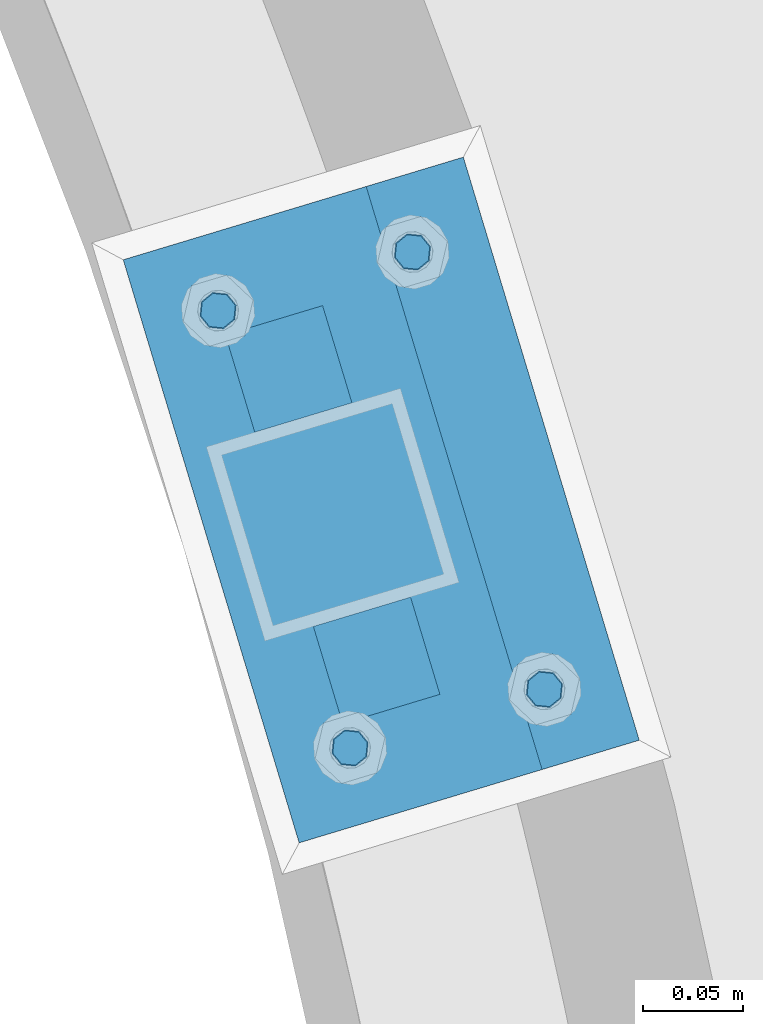
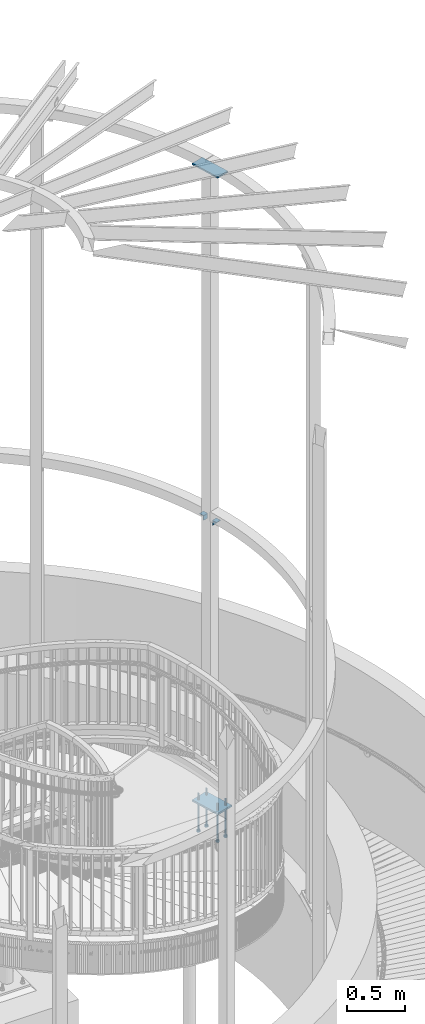
# One storey, part 512 of 975: 9 beams.
"""IFC2X3 building model written with IfcOpenShell, lengths in millimetres."""

from ifc_helpers import new_model, si_unit, frame, origin_with_axes, place, context, subcontext, project, spatial, faceted_brep, material, type_object, element, save


model = new_model("IFC2X3")

# Units and contexts
model_context = context("Model", 3, precision=1e-05, world=origin_with_axes())
body_context = subcontext(model_context, "Body", "Model", "MODEL_VIEW")
ifc_project = project(units=[si_unit("LENGTHUNIT", "METRE", prefix="MILLI"), si_unit("AREAUNIT", "SQUARE_METRE"), si_unit("VOLUMEUNIT", "CUBIC_METRE"), si_unit("MASSUNIT", "GRAM", prefix="KILO"), si_unit("TIMEUNIT", "SECOND"), si_unit("PLANEANGLEUNIT", "RADIAN"), si_unit("SOLIDANGLEUNIT", "STERADIAN"), si_unit("THERMODYNAMICTEMPERATUREUNIT", "DEGREE_CELSIUS"), si_unit("LUMINOUSINTENSITYUNIT", "LUMEN")], contexts=[model_context])

# Site, building, storey
site_placement = place(None, origin_with_axes())
site = spatial("IfcSite", under=ifc_project, at=site_placement, CompositionType="ELEMENT")
building_placement = place(site_placement, origin_with_axes())
building = spatial("IfcBuilding", under=site, at=building_placement, Name="Undefined", CompositionType="ELEMENT")
storey_placement = place(building_placement, origin_with_axes())
storey = spatial("IfcBuildingStorey", under=building, at=storey_placement, Name="Undefined", CompositionType="ELEMENT", Elevation=0.0)

# Beams
ifc_material_1 = material(Name="STEEL/A36")
beam_type_1 = type_object("IfcBeamType", Name="L2X2X1/4", PredefinedType="NOTDEFINED")
for number, where, z_axis, x_axis, name in (
    (1, (37884.2855508287, 4274.3875025586, 4445.0), (0.288864709123643, -0.957369928409553, 0.0), (0.957369928409554, 0.288864709123642, 0.0), "ANGLE"),
    (2, (37888.8969615215, 4434.96500687169, 4445.0), (-0.288864709123643, 0.957369928409553, 0.0), (-0.957369928409554, -0.288864709123642, 0.0), "ANGLE"),
):
    element("IfcBeam", number, at=place(storey_placement, frame(where, z_axis=z_axis, x_axis=x_axis)), inside=storey, type_object=beam_type_1, material=ifc_material_1, Name=name, ObjectType="L2X2X1/4", context=body_context, shape_type="Brep", body=[
        faceted_brep([(0.0, 25.3999999999724, -25.4000000000342), (0.0, 25.400000000016, 25.4000000000196), (50.8000000000102, 25.3999999999996, 25.4000000000015), (50.7999999999411, 25.3999999999996, -25.4000000000487), (3.27418092638254e-11, 19.0500000000002, 25.4000000000269), (50.8000000000102, 19.0500000000002, 25.4000000000015), (-2.5465851649642e-11, 19.0500000000002, -19.0500000000211), (50.7999999999483, 19.0500000000002, -19.0500000000429), (-2.5465851649642e-11, -25.3999999999996, -19.0500000000211), (50.7999999999483, -25.3999999999996, -19.0500000000429), (0.0, -25.400000000016, -25.4000000000196), (50.7999999999411, -25.3999999999996, -25.4000000000487)], [[[0, 1, 2, 3]], [[1, 4, 5, 2]], [[4, 6, 7, 5]], [[6, 8, 9, 7]], [[8, 10, 11, 9]], [[10, 0, 3, 11]], [[5, 7, 9, 11, 3, 2]], [[10, 8, 6, 4, 1, 0]]]),
    ])
beam_type_2 = type_object("IfcBeamType", PredefinedType="NOTDEFINED")
beam_1_placement = place(storey_placement, frame((37842.5682745048, 4500.57943180456, 8170.8625), z_axis=(-0.957369928409554, -0.288864709123642, 0.0), x_axis=(0.288864709123643, -0.957369928409553, 0.0)))
element("IfcBeam", 3, at=beam_1_placement, inside=storey, type_object=beam_type_2, material=ifc_material_1, Name="PLATE", context=body_context, shape_type="Brep", body=[
    faceted_brep([(0.0, 7.9375, -63.5), (0.0, 7.9375, 63.5), (304.799999999529, 7.9375, 63.5), (304.799999999529, 7.9375, -63.5), (0.0, -7.9375, 63.5), (304.799999999529, -7.9375, 63.5), (0.0, -7.9375, -63.5), (304.799999999529, -7.9375, -63.5)], [[[0, 1, 2, 3]], [[1, 4, 5, 2]], [[4, 6, 7, 5]], [[6, 0, 3, 7]], [[5, 7, 3, 2]], [[6, 4, 1, 0]]]),
])
ifc_material_2 = material(Name="STEEL/F1554-36")
beam_type_3 = type_object("IfcBeamType", PredefinedType="NOTDEFINED")
beam_2_placement = place(storey_placement, frame((37895.2912979753, 4237.91170244039, 1371.6), z_axis=(0.288864709123643, -0.957369928409553, 0.0), x_axis=(0.0, 0.0, -1.0)))
element("IfcBeam", 4, at=beam_2_placement, inside=storey, type_object=beam_type_3, material=ifc_material_2, Name="HEADED_ANCHOR_BOLT", context=body_context, shape_type="Brep", body=[
    faceted_brep([(260.34375, -9.13000011445183, 15.8100004195221), (260.34375, -18.2600002289691, -1.45519152283669e-11), (279.393749999999, -18.2600002289691, -1.45519152283669e-11), (279.393749999999, -9.13000011445183, 15.8100004195221), (260.34375, 9.13000011451732, 15.8100004195403), (279.393749999999, 9.13000011451732, 15.8100004195403), (260.34375, 18.2600002289728, 1.81898940354586e-11), (279.393749999999, 18.2600002289728, 1.81898940354586e-11), (260.34375, 9.13000011445547, -15.8100004195221), (279.393749999999, 9.13000011445547, -15.8100004195221), (260.34375, -9.13000011451732, -15.8100004195367), (279.393749999999, -9.13000011451732, -15.8100004195367), (260.34375, -4.47768005528269, 9.29799844174704), (260.34375, -8.06850066050174, 6.43441456486471), (260.34375, -10.0612557562381, 2.29641597050068), (260.34375, -10.0612557562454, -2.29641597051523), (260.34375, -8.06850066052721, -6.43441456487926), (260.34375, -4.47768005531907, -9.29799844175068), (260.34375, -1.81898940354586e-11, -10.319999694766), (260.34375, 4.47768005528633, -9.2979984417434), (260.34375, 8.06850066050174, -6.43441456486471), (260.34375, 10.0612557562381, -2.29641597050068), (260.34375, 10.0612557562454, 2.29641597051886), (260.34375, 8.06850066052357, 6.4344145648829), (260.34375, 4.47768005532271, 9.29799844175432), (260.34375, 2.18278728425503e-11, 10.3199996947696), (279.393749999999, 2.18278728425503e-11, 10.3199996947696), (279.393749999999, -4.47768005528269, 9.29799844174704), (279.393749999999, -8.06850066050174, 6.43441456486471), (279.393749999999, -10.0612557562381, 2.29641597050068), (279.393749999999, -10.0612557562454, -2.29641597051523), (279.393749999999, -8.06850066052721, -6.43441456487926), (279.393749999999, -4.47768005531907, -9.29799844175068), (279.393749999999, -1.81898940354586e-11, -10.319999694766), (279.393749999999, 4.47768005528633, -9.2979984417434), (279.393749999999, 8.06850066050174, -6.43441456486471), (279.393749999999, 10.0612557562381, -2.29641597050068), (279.393749999999, 10.0612557562454, 2.29641597051886), (279.393749999999, 8.06850066052357, 6.4344145648829), (279.393749999999, 4.47768005532271, 9.29799844175432), (0.0, -6.73519209080223, 6.73519209080186), (0.0, -9.52499999999964, 0.0), (279.400000000001, -9.52499999999782, -3.63797880709171e-12), (279.400000000001, -6.73519209079313, 6.73519209079313), (-9.87109982941227e-13, -1.20792265079217e-13, 9.52499961853027), (279.400000000001, 1.09139364212751e-11, 9.52499999999054), (0.0, 6.73519209080223, 6.73519209080186), (279.400000000001, 6.73519209081132, 6.73519209079677), (0.0, 9.52499999999964, 0.0), (279.400000000001, 9.52500000000146, 3.63797880709171e-12), (0.0, 6.73519209080223, -6.73519209080186), (279.400000000001, 6.73519209079677, -6.73519209079313), (2.95075507493764e-12, -1.20792265079217e-13, -9.52499961853027), (279.400000000001, -1.09139364212751e-11, -9.5249999999869), (-126.99791499542, -6.36396103070001, 6.3639610306418), (-126.99791499542, 1.81898940354586e-11, 8.99999999995271), (-126.99791499542, 6.36396103072184, 6.36396103065272), (-126.99791499542, 9.00000000004366, 1.09139364212751e-11), (-126.99791499542, 6.36396103069637, -6.3639610306418), (-126.99791499542, -1.81898940354586e-11, -8.99999999995271), (-126.99791499542, -6.36396103072184, -6.36396103064908), (-126.99791499542, -9.00000000004002, -7.27595761418343e-12), (0.0149743263646087, 6.36396103067818, -6.36396103067909), (0.0149743263646087, 0.0, -9.0), (0.0149743263646087, -6.36396103067818, -6.36396103067909), (0.0149743263987148, -8.9999995411581, -1.00796984270346e-06), (0.0149743263646087, -6.36396103067818, 6.36396103067909), (0.0149743263646087, 0.0, 9.0), (0.0149743263646087, 6.36396103067818, 6.36396103067909), (0.0149743263987148, 9.0000004588419, -1.00796984270346e-06), (0.0, -6.73519209080223, -6.73519209080186), (279.400000000001, -6.73519209080769, -6.73519209079677)], [[[0, 1, 2, 3]], [[4, 0, 3, 5]], [[6, 4, 5, 7]], [[8, 6, 7, 9]], [[10, 8, 9, 11]], [[0, 4, 6, 8, 10, 1], [12, 13, 14, 15, 16, 17, 18, 19, 20, 21, 22, 23, 24, 25]], [[12, 25, 26, 27]], [[13, 12, 27, 28]], [[14, 13, 28, 29]], [[15, 14, 29, 30]], [[16, 15, 30, 31]], [[17, 16, 31, 32]], [[18, 17, 32, 33]], [[19, 18, 33, 34]], [[20, 19, 34, 35]], [[21, 20, 35, 36]], [[22, 21, 36, 37]], [[23, 22, 37, 38]], [[24, 23, 38, 39]], [[25, 24, 39, 26]], [[9, 7, 5, 3, 2, 11], [38, 37, 36, 35, 34, 33, 32, 31, 30, 29, 28, 27, 26, 39]], [[1, 10, 11, 2]], [[40, 41, 42, 43]], [[44, 40, 43, 45]], [[46, 44, 45, 47]], [[48, 46, 47, 49]], [[50, 48, 49, 51]], [[52, 50, 51, 53]], [[54, 55, 56, 57, 58, 59, 60, 61]], [[59, 58, 62, 63]], [[60, 59, 63, 64]], [[61, 60, 64, 65]], [[54, 61, 65, 66]], [[55, 54, 66, 67]], [[56, 55, 67, 68]], [[57, 56, 68, 69]], [[58, 57, 69, 62]], [[40, 44, 46, 48, 50, 52, 70, 41], [68, 67, 66, 65, 64, 63, 62, 69]], [[41, 70, 71, 42]], [[53, 51, 49, 47, 45, 43, 42, 71]], [[70, 52, 53, 71]]]),
])
beam_3_placement = place(storey_placement, frame((37992.5600809474, 4267.26036270437, 1371.6), z_axis=(-0.288864709123643, 0.957369928409553, 0.0), x_axis=(0.0, 0.0, -1.0)))
element("IfcBeam", 5, at=beam_3_placement, inside=storey, type_object=beam_type_3, material=ifc_material_2, Name="HEADED_ANCHOR_BOLT", context=body_context, shape_type="Brep", body=[
    faceted_brep([(260.34375, -9.13000011445183, 15.8100004195221), (260.34375, -18.2600002289691, -1.45519152283669e-11), (279.393749999999, -18.2600002289691, -1.45519152283669e-11), (279.393749999999, -9.13000011445183, 15.8100004195221), (260.34375, 9.13000011451732, 15.8100004195403), (279.393749999999, 9.13000011451732, 15.8100004195403), (260.34375, 18.2600002289728, 1.81898940354586e-11), (279.393749999999, 18.2600002289728, 1.81898940354586e-11), (260.34375, 9.13000011445547, -15.8100004195221), (279.393749999999, 9.13000011445547, -15.8100004195221), (260.34375, -9.13000011451732, -15.8100004195367), (279.393749999999, -9.13000011451732, -15.8100004195367), (260.34375, -4.47768005528269, 9.29799844174704), (260.34375, -8.06850066050174, 6.43441456486471), (260.34375, -10.0612557562381, 2.29641597050068), (260.34375, -10.0612557562454, -2.29641597051523), (260.34375, -8.06850066052721, -6.43441456487926), (260.34375, -4.47768005531907, -9.29799844175068), (260.34375, -1.81898940354586e-11, -10.319999694766), (260.34375, 4.47768005528633, -9.2979984417434), (260.34375, 8.06850066050174, -6.43441456486471), (260.34375, 10.0612557562381, -2.29641597050068), (260.34375, 10.0612557562454, 2.29641597051886), (260.34375, 8.06850066052357, 6.4344145648829), (260.34375, 4.47768005532271, 9.29799844175432), (260.34375, 2.18278728425503e-11, 10.3199996947696), (279.393749999999, 2.18278728425503e-11, 10.3199996947696), (279.393749999999, -4.47768005528269, 9.29799844174704), (279.393749999999, -8.06850066050174, 6.43441456486471), (279.393749999999, -10.0612557562381, 2.29641597050068), (279.393749999999, -10.0612557562454, -2.29641597051523), (279.393749999999, -8.06850066052721, -6.43441456487926), (279.393749999999, -4.47768005531907, -9.29799844175068), (279.393749999999, -1.81898940354586e-11, -10.319999694766), (279.393749999999, 4.47768005528633, -9.2979984417434), (279.393749999999, 8.06850066050174, -6.43441456486471), (279.393749999999, 10.0612557562381, -2.29641597050068), (279.393749999999, 10.0612557562454, 2.29641597051886), (279.393749999999, 8.06850066052357, 6.4344145648829), (279.393749999999, 4.47768005532271, 9.29799844175432), (0.0, -6.73519209080223, 6.73519209080186), (0.0, -9.52499999999964, 0.0), (279.400000000001, -9.52499999999782, -3.63797880709171e-12), (279.400000000001, -6.73519209079313, 6.73519209079313), (-9.87109982941227e-13, -1.20792265079217e-13, 9.52499961853027), (279.400000000001, 1.09139364212751e-11, 9.52499999999054), (0.0, 6.73519209080223, 6.73519209080186), (279.400000000001, 6.73519209081132, 6.73519209079677), (0.0, 9.52499999999964, 0.0), (279.400000000001, 9.52500000000146, 3.63797880709171e-12), (0.0, 6.73519209080223, -6.73519209080186), (279.400000000001, 6.73519209079677, -6.73519209079313), (2.95075507493764e-12, -1.20792265079217e-13, -9.52499961853027), (279.400000000001, -1.09139364212751e-11, -9.5249999999869), (-126.99791499542, -6.36396103070001, 6.3639610306418), (-126.99791499542, 1.81898940354586e-11, 8.99999999995271), (-126.99791499542, 6.36396103072184, 6.36396103065272), (-126.99791499542, 9.00000000004366, 1.09139364212751e-11), (-126.99791499542, 6.36396103069637, -6.3639610306418), (-126.99791499542, -1.81898940354586e-11, -8.99999999995271), (-126.99791499542, -6.36396103072184, -6.36396103064908), (-126.99791499542, -9.00000000004002, -7.27595761418343e-12), (0.0149743263646087, 6.36396103067818, -6.36396103067909), (0.0149743263646087, 0.0, -9.0), (0.0149743263646087, -6.36396103067818, -6.36396103067909), (0.0149743263987148, -8.9999995411581, -1.00796984270346e-06), (0.0149743263646087, -6.36396103067818, 6.36396103067909), (0.0149743263646087, 0.0, 9.0), (0.0149743263646087, 6.36396103067818, 6.36396103067909), (0.0149743263987148, 9.0000004588419, -1.00796984270346e-06), (0.0, -6.73519209080223, -6.73519209080186), (279.400000000001, -6.73519209080769, -6.73519209079677)], [[[0, 1, 2, 3]], [[4, 0, 3, 5]], [[6, 4, 5, 7]], [[8, 6, 7, 9]], [[10, 8, 9, 11]], [[0, 4, 6, 8, 10, 1], [12, 13, 14, 15, 16, 17, 18, 19, 20, 21, 22, 23, 24, 25]], [[12, 25, 26, 27]], [[13, 12, 27, 28]], [[14, 13, 28, 29]], [[15, 14, 29, 30]], [[16, 15, 30, 31]], [[17, 16, 31, 32]], [[18, 17, 32, 33]], [[19, 18, 33, 34]], [[20, 19, 34, 35]], [[21, 20, 35, 36]], [[22, 21, 36, 37]], [[23, 22, 37, 38]], [[24, 23, 38, 39]], [[25, 24, 39, 26]], [[9, 7, 5, 3, 2, 11], [38, 37, 36, 35, 34, 33, 32, 31, 30, 29, 28, 27, 26, 39]], [[1, 10, 11, 2]], [[40, 41, 42, 43]], [[44, 40, 43, 45]], [[46, 44, 45, 47]], [[48, 46, 47, 49]], [[50, 48, 49, 51]], [[52, 50, 51, 53]], [[54, 55, 56, 57, 58, 59, 60, 61]], [[59, 58, 62, 63]], [[60, 59, 63, 64]], [[61, 60, 64, 65]], [[54, 61, 65, 66]], [[55, 54, 66, 67]], [[56, 55, 67, 68]], [[57, 56, 68, 69]], [[58, 57, 69, 62]], [[40, 44, 46, 48, 50, 52, 70, 41], [68, 67, 66, 65, 64, 63, 62, 69]], [[41, 70, 71, 42]], [[53, 51, 49, 47, 45, 43, 42, 71]], [[70, 52, 53, 71]]]),
])
beam_4_placement = place(storey_placement, frame((37829.2568255331, 4456.76646809366, 1371.6), z_axis=(0.288864709123643, -0.957369928409553, 0.0), x_axis=(0.0, 0.0, -1.0)))
element("IfcBeam", 6, at=beam_4_placement, inside=storey, type_object=beam_type_3, material=ifc_material_2, Name="HEADED_ANCHOR_BOLT", context=body_context, shape_type="Brep", body=[
    faceted_brep([(260.34375, -9.13000011445183, 15.8100004195221), (260.34375, -18.2600002289691, -1.45519152283669e-11), (279.393749999999, -18.2600002289691, -1.45519152283669e-11), (279.393749999999, -9.13000011445183, 15.8100004195221), (260.34375, 9.13000011451732, 15.8100004195403), (279.393749999999, 9.13000011451732, 15.8100004195403), (260.34375, 18.2600002289728, 1.81898940354586e-11), (279.393749999999, 18.2600002289728, 1.81898940354586e-11), (260.34375, 9.13000011445547, -15.8100004195221), (279.393749999999, 9.13000011445547, -15.8100004195221), (260.34375, -9.13000011451732, -15.8100004195367), (279.393749999999, -9.13000011451732, -15.8100004195367), (260.34375, -4.47768005528269, 9.29799844174704), (260.34375, -8.06850066050174, 6.43441456486471), (260.34375, -10.0612557562381, 2.29641597050068), (260.34375, -10.0612557562454, -2.29641597051523), (260.34375, -8.06850066052721, -6.43441456487926), (260.34375, -4.47768005531907, -9.29799844175068), (260.34375, -1.81898940354586e-11, -10.319999694766), (260.34375, 4.47768005528633, -9.2979984417434), (260.34375, 8.06850066050174, -6.43441456486471), (260.34375, 10.0612557562381, -2.29641597050068), (260.34375, 10.0612557562454, 2.29641597051886), (260.34375, 8.06850066052357, 6.4344145648829), (260.34375, 4.47768005532271, 9.29799844175432), (260.34375, 2.18278728425503e-11, 10.3199996947696), (279.393749999999, 2.18278728425503e-11, 10.3199996947696), (279.393749999999, -4.47768005528269, 9.29799844174704), (279.393749999999, -8.06850066050174, 6.43441456486471), (279.393749999999, -10.0612557562381, 2.29641597050068), (279.393749999999, -10.0612557562454, -2.29641597051523), (279.393749999999, -8.06850066052721, -6.43441456487926), (279.393749999999, -4.47768005531907, -9.29799844175068), (279.393749999999, -1.81898940354586e-11, -10.319999694766), (279.393749999999, 4.47768005528633, -9.2979984417434), (279.393749999999, 8.06850066050174, -6.43441456486471), (279.393749999999, 10.0612557562381, -2.29641597050068), (279.393749999999, 10.0612557562454, 2.29641597051886), (279.393749999999, 8.06850066052357, 6.4344145648829), (279.393749999999, 4.47768005532271, 9.29799844175432), (0.0, -6.73519209080223, 6.73519209080186), (0.0, -9.52499999999964, 0.0), (279.400000000001, -9.52499999999782, -3.63797880709171e-12), (279.400000000001, -6.73519209079313, 6.73519209079313), (-9.87109982941227e-13, -1.20792265079217e-13, 9.52499961853027), (279.400000000001, 1.09139364212751e-11, 9.52499999999054), (0.0, 6.73519209080223, 6.73519209080186), (279.400000000001, 6.73519209081132, 6.73519209079677), (0.0, 9.52499999999964, 0.0), (279.400000000001, 9.52500000000146, 3.63797880709171e-12), (0.0, 6.73519209080223, -6.73519209080186), (279.400000000001, 6.73519209079677, -6.73519209079313), (2.95075507493764e-12, -1.20792265079217e-13, -9.52499961853027), (279.400000000001, -1.09139364212751e-11, -9.5249999999869), (-126.99791499542, -6.36396103070001, 6.3639610306418), (-126.99791499542, 1.81898940354586e-11, 8.99999999995271), (-126.99791499542, 6.36396103072184, 6.36396103065272), (-126.99791499542, 9.00000000004366, 1.09139364212751e-11), (-126.99791499542, 6.36396103069637, -6.3639610306418), (-126.99791499542, -1.81898940354586e-11, -8.99999999995271), (-126.99791499542, -6.36396103072184, -6.36396103064908), (-126.99791499542, -9.00000000004002, -7.27595761418343e-12), (0.0149743263646087, 6.36396103067818, -6.36396103067909), (0.0149743263646087, 0.0, -9.0), (0.0149743263646087, -6.36396103067818, -6.36396103067909), (0.0149743263987148, -8.9999995411581, -1.00796984270346e-06), (0.0149743263646087, -6.36396103067818, 6.36396103067909), (0.0149743263646087, 0.0, 9.0), (0.0149743263646087, 6.36396103067818, 6.36396103067909), (0.0149743263987148, 9.0000004588419, -1.00796984270346e-06), (0.0, -6.73519209080223, -6.73519209080186), (279.400000000001, -6.73519209080769, -6.73519209079677)], [[[0, 1, 2, 3]], [[4, 0, 3, 5]], [[6, 4, 5, 7]], [[8, 6, 7, 9]], [[10, 8, 9, 11]], [[0, 4, 6, 8, 10, 1], [12, 13, 14, 15, 16, 17, 18, 19, 20, 21, 22, 23, 24, 25]], [[12, 25, 26, 27]], [[13, 12, 27, 28]], [[14, 13, 28, 29]], [[15, 14, 29, 30]], [[16, 15, 30, 31]], [[17, 16, 31, 32]], [[18, 17, 32, 33]], [[19, 18, 33, 34]], [[20, 19, 34, 35]], [[21, 20, 35, 36]], [[22, 21, 36, 37]], [[23, 22, 37, 38]], [[24, 23, 38, 39]], [[25, 24, 39, 26]], [[9, 7, 5, 3, 2, 11], [38, 37, 36, 35, 34, 33, 32, 31, 30, 29, 28, 27, 26, 39]], [[1, 10, 11, 2]], [[40, 41, 42, 43]], [[44, 40, 43, 45]], [[46, 44, 45, 47]], [[48, 46, 47, 49]], [[50, 48, 49, 51]], [[52, 50, 51, 53]], [[54, 55, 56, 57, 58, 59, 60, 61]], [[59, 58, 62, 63]], [[60, 59, 63, 64]], [[61, 60, 64, 65]], [[54, 61, 65, 66]], [[55, 54, 66, 67]], [[56, 55, 67, 68]], [[57, 56, 68, 69]], [[58, 57, 69, 62]], [[40, 44, 46, 48, 50, 52, 70, 41], [68, 67, 66, 65, 64, 63, 62, 69]], [[41, 70, 71, 42]], [[53, 51, 49, 47, 45, 43, 42, 71]], [[70, 52, 53, 71]]]),
])
beam_5_placement = place(storey_placement, frame((37926.5256085057, 4486.11512835611, 1371.6), z_axis=(-0.288864709123643, 0.957369928409553, 0.0), x_axis=(0.0, 0.0, -1.0)))
element("IfcBeam", 7, at=beam_5_placement, inside=storey, type_object=beam_type_3, material=ifc_material_2, Name="HEADED_ANCHOR_BOLT", context=body_context, shape_type="Brep", body=[
    faceted_brep([(260.34375, -9.13000011445183, 15.8100004195221), (260.34375, -18.2600002289691, -1.45519152283669e-11), (279.393749999999, -18.2600002289691, -1.45519152283669e-11), (279.393749999999, -9.13000011445183, 15.8100004195221), (260.34375, 9.13000011451732, 15.8100004195403), (279.393749999999, 9.13000011451732, 15.8100004195403), (260.34375, 18.2600002289728, 1.81898940354586e-11), (279.393749999999, 18.2600002289728, 1.81898940354586e-11), (260.34375, 9.13000011445547, -15.8100004195221), (279.393749999999, 9.13000011445547, -15.8100004195221), (260.34375, -9.13000011451732, -15.8100004195367), (279.393749999999, -9.13000011451732, -15.8100004195367), (260.34375, -4.47768005528269, 9.29799844174704), (260.34375, -8.06850066050174, 6.43441456486471), (260.34375, -10.0612557562381, 2.29641597050068), (260.34375, -10.0612557562454, -2.29641597051523), (260.34375, -8.06850066052721, -6.43441456487926), (260.34375, -4.47768005531907, -9.29799844175068), (260.34375, -1.81898940354586e-11, -10.319999694766), (260.34375, 4.47768005528633, -9.2979984417434), (260.34375, 8.06850066050174, -6.43441456486471), (260.34375, 10.0612557562381, -2.29641597050068), (260.34375, 10.0612557562454, 2.29641597051886), (260.34375, 8.06850066052357, 6.4344145648829), (260.34375, 4.47768005532271, 9.29799844175432), (260.34375, 2.18278728425503e-11, 10.3199996947696), (279.393749999999, 2.18278728425503e-11, 10.3199996947696), (279.393749999999, -4.47768005528269, 9.29799844174704), (279.393749999999, -8.06850066050174, 6.43441456486471), (279.393749999999, -10.0612557562381, 2.29641597050068), (279.393749999999, -10.0612557562454, -2.29641597051523), (279.393749999999, -8.06850066052721, -6.43441456487926), (279.393749999999, -4.47768005531907, -9.29799844175068), (279.393749999999, -1.81898940354586e-11, -10.319999694766), (279.393749999999, 4.47768005528633, -9.2979984417434), (279.393749999999, 8.06850066050174, -6.43441456486471), (279.393749999999, 10.0612557562381, -2.29641597050068), (279.393749999999, 10.0612557562454, 2.29641597051886), (279.393749999999, 8.06850066052357, 6.4344145648829), (279.393749999999, 4.47768005532271, 9.29799844175432), (0.0, -6.73519209080223, 6.73519209080186), (0.0, -9.52499999999964, 0.0), (279.400000000001, -9.52499999999782, -3.63797880709171e-12), (279.400000000001, -6.73519209079313, 6.73519209079313), (-9.87109982941227e-13, -1.20792265079217e-13, 9.52499961853027), (279.400000000001, 1.09139364212751e-11, 9.52499999999054), (0.0, 6.73519209080223, 6.73519209080186), (279.400000000001, 6.73519209081132, 6.73519209079677), (0.0, 9.52499999999964, 0.0), (279.400000000001, 9.52500000000146, 3.63797880709171e-12), (0.0, 6.73519209080223, -6.73519209080186), (279.400000000001, 6.73519209079677, -6.73519209079313), (2.95075507493764e-12, -1.20792265079217e-13, -9.52499961853027), (279.400000000001, -1.09139364212751e-11, -9.5249999999869), (-126.99791499542, -6.36396103070001, 6.3639610306418), (-126.99791499542, 1.81898940354586e-11, 8.99999999995271), (-126.99791499542, 6.36396103072184, 6.36396103065272), (-126.99791499542, 9.00000000004366, 1.09139364212751e-11), (-126.99791499542, 6.36396103069637, -6.3639610306418), (-126.99791499542, -1.81898940354586e-11, -8.99999999995271), (-126.99791499542, -6.36396103072184, -6.36396103064908), (-126.99791499542, -9.00000000004002, -7.27595761418343e-12), (0.0149743263646087, 6.36396103067818, -6.36396103067909), (0.0149743263646087, 0.0, -9.0), (0.0149743263646087, -6.36396103067818, -6.36396103067909), (0.0149743263987148, -8.9999995411581, -1.00796984270346e-06), (0.0149743263646087, -6.36396103067818, 6.36396103067909), (0.0149743263646087, 0.0, 9.0), (0.0149743263646087, 6.36396103067818, 6.36396103067909), (0.0149743263987148, 9.0000004588419, -1.00796984270346e-06), (0.0, -6.73519209080223, -6.73519209080186), (279.400000000001, -6.73519209080769, -6.73519209079677)], [[[0, 1, 2, 3]], [[4, 0, 3, 5]], [[6, 4, 5, 7]], [[8, 6, 7, 9]], [[10, 8, 9, 11]], [[0, 4, 6, 8, 10, 1], [12, 13, 14, 15, 16, 17, 18, 19, 20, 21, 22, 23, 24, 25]], [[12, 25, 26, 27]], [[13, 12, 27, 28]], [[14, 13, 28, 29]], [[15, 14, 29, 30]], [[16, 15, 30, 31]], [[17, 16, 31, 32]], [[18, 17, 32, 33]], [[19, 18, 33, 34]], [[20, 19, 34, 35]], [[21, 20, 35, 36]], [[22, 21, 36, 37]], [[23, 22, 37, 38]], [[24, 23, 38, 39]], [[25, 24, 39, 26]], [[9, 7, 5, 3, 2, 11], [38, 37, 36, 35, 34, 33, 32, 31, 30, 29, 28, 27, 26, 39]], [[1, 10, 11, 2]], [[40, 41, 42, 43]], [[44, 40, 43, 45]], [[46, 44, 45, 47]], [[48, 46, 47, 49]], [[50, 48, 49, 51]], [[52, 50, 51, 53]], [[54, 55, 56, 57, 58, 59, 60, 61]], [[59, 58, 62, 63]], [[60, 59, 63, 64]], [[61, 60, 64, 65]], [[54, 61, 65, 66]], [[55, 54, 66, 67]], [[56, 55, 67, 68]], [[57, 56, 68, 69]], [[58, 57, 69, 62]], [[40, 44, 46, 48, 50, 52, 70, 41], [68, 67, 66, 65, 64, 63, 62, 69]], [[41, 70, 71, 42]], [[53, 51, 49, 47, 45, 43, 42, 71]], [[70, 52, 53, 71]]]),
])
beam_type_4 = type_object("IfcBeamType", PredefinedType="NOTDEFINED")
beam_6_placement = place(storey_placement, frame((37866.8854707308, 4507.9165954222, 1419.225), z_axis=(0.957369928409554, 0.288864709123642, 0.0), x_axis=(0.288864709123643, -0.957369928409553, 0.0)))
element("IfcBeam", 8, at=beam_6_placement, inside=storey, type_object=beam_type_4, material=ifc_material_1, Name="PLATE", context=body_context, shape_type="Brep", body=[
    faceted_brep([(0.0, 9.52499999999964, -88.9000000000015), (0.0, 9.52499999999964, 88.9000000000015), (304.800000000429, 9.52500000000009, 88.9000000003653), (304.800000000414, 9.52500000000009, -88.8999999996704), (0.0, -9.52499999999964, 88.9000000000015), (304.800000000429, -9.52500000000009, 88.9000000003653), (0.0, -9.52499999999964, -88.9000000000015), (304.800000000414, -9.52500000000009, -88.8999999996704)], [[[0, 1, 2, 3]], [[1, 4, 5, 2]], [[4, 6, 7, 5]], [[6, 0, 3, 7]], [[5, 7, 3, 2]], [[6, 4, 1, 0]]]),
])
beam_type_5 = type_object("IfcBeamType", PredefinedType="NOTDEFINED")
beam_7_placement = place(storey_placement, frame((37866.8854707043, 4507.9165954142, 1411.2875), z_axis=(0.957369928409554, 0.288864709123642, 0.0), x_axis=(0.288864709123643, -0.957369928409553, 0.0)))
element("IfcBeam", 9, at=beam_7_placement, inside=storey, type_object=beam_type_5, material=ifc_material_1, Name="TEMPLATE", context=body_context, shape_type="Brep", body=[
    faceted_brep([(-1.09139364212751e-11, 1.58750000000009, -88.900000000016), (3.63797880709171e-12, 1.58750000000009, 88.9000000000196), (304.800000000418, 1.58750000000009, 88.9000000003762), (304.800000000399, 1.58750000000009, -88.8999999996631), (3.63797880709171e-12, -1.58750000000009, 88.9000000000196), (304.800000000418, -1.58750000000009, 88.9000000003762), (-1.09139364212751e-11, -1.58750000000009, -88.900000000016), (304.800000000399, -1.58750000000009, -88.8999999996631)], [[[0, 1, 2, 3]], [[1, 4, 5, 2]], [[4, 6, 7, 5]], [[6, 0, 3, 7]], [[5, 7, 3, 2]], [[6, 4, 1, 0]]]),
])

save(model, "model.ifc")
